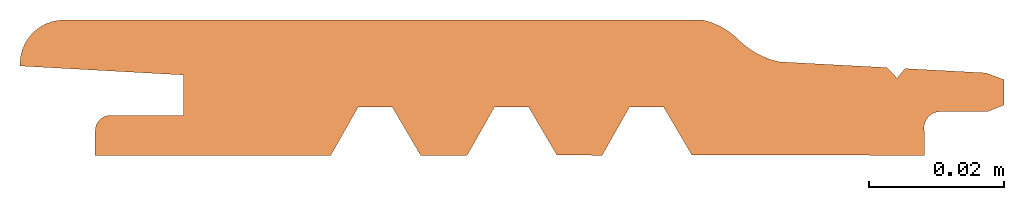
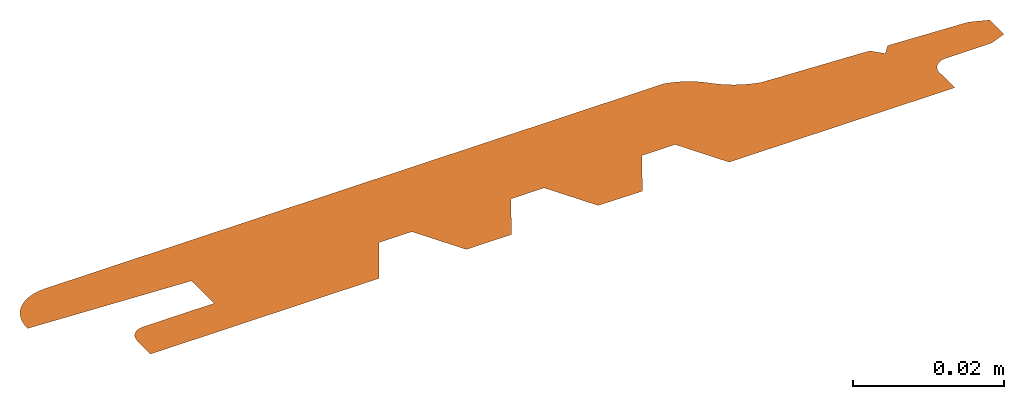
# One storey: 1 proxy.
"""IFC2X3 building model written with IfcOpenShell, lengths in millimetres."""

import ifcopenshell
import ifcopenshell.guid

model = None  # the IFC model being written
_history = None  # IfcOwnerHistory: only IFC2X3 demands one
_inside = {}  # id of a spatial element -> (the spatial element, [elements in it])
_under = {}  # id of a project, library or spatial element -> (it, [spatial elements below it])
_declared = {}  # id of a project -> (the project, [libraries it declares])
_typed = {}  # id of a type object -> (the type object, [elements of that type])
_made_of = {}  # id of a material, layer set ... -> (it, [elements and type objects made of it])


def new_model(schema):
    """Start an empty IFC model of exactly this schema.

    Asked for "IFC4X3", IfcOpenShell would pick the latest addendum, in which some entities
    have other attributes; the version numbers below select the first issue.
    IFC2X3 requires an IfcOwnerHistory on every rooted entity: one is made here for all.
    """
    global model, _history
    if schema == "IFC4X3":
        model = ifcopenshell.file(schema_version=(4, 3, 0, 0))
    else:
        model = ifcopenshell.file(schema=schema)
    _inside.clear()
    _under.clear()
    _declared.clear()
    _typed.clear()
    _made_of.clear()
    _history = None
    if model.schema == "IFC2X3":
        org = make("IfcOrganization", Name="unknown")
        user = make(
            "IfcPersonAndOrganization",
            ThePerson=make("IfcPerson", FamilyName="unknown"),
            TheOrganization=org,
        )
        app = make(
            "IfcApplication",
            ApplicationDeveloper=org,
            Version="unknown",
            ApplicationFullName="unknown",
            ApplicationIdentifier="unknown",
        )
        _history = make(
            "IfcOwnerHistory",
            OwningUser=user,
            OwningApplication=app,
            ChangeAction="ADDED",
            CreationDate=0,
        )
    return model


def make(cls, **values):
    """One entity of the class cls with the attributes given. An attribute that is None is left unset."""
    return model.create_entity(
        cls, **{name: value for name, value in values.items() if value is not None}
    )


def entity(cls, *values):
    """Any entity or typed value of the class cls, its attributes in the order of the schema. None: left unset."""
    e = model.create_entity(cls)
    for i, value in enumerate(values):
        if value is not None:
            e[i] = value
    return e


def rooted(cls, **values):
    """An entity with a GlobalId (a new one), such as an element, a storey or a relation."""
    return make(cls, GlobalId=ifcopenshell.guid.new(), OwnerHistory=_history, **values)


def si_unit(unit_type, name, prefix=None):
    """IfcSIUnit, for example si_unit("LENGTHUNIT", "METRE", prefix="MILLI")."""
    return make("IfcSIUnit", UnitType=unit_type, Prefix=prefix, Name=name)


def converted_unit(unit_type, name, factor, base, dimensions=None, offset=None):
    """IfcConversionBasedUnit, such as the inch: factor (a typed value) times the base unit."""
    return make(
        "IfcConversionBasedUnit"
        if offset is None
        else "IfcConversionBasedUnitWithOffset",
        ConversionOffset=offset,
        Dimensions=None
        if dimensions is None
        else entity("IfcDimensionalExponents", *dimensions),
        UnitType=unit_type,
        Name=name,
        ConversionFactor=make(
            "IfcMeasureWithUnit", ValueComponent=factor, UnitComponent=base
        ),
    )


def assignment(units):
    """IfcUnitAssignment: the units of a project."""
    return None if units is None else make("IfcUnitAssignment", Units=units)


def point(xyz):
    """IfcCartesianPoint."""
    return None if xyz is None else make("IfcCartesianPoint", Coordinates=xyz)


def direction(xyz):
    """IfcDirection."""
    return None if xyz is None else make("IfcDirection", DirectionRatios=xyz)


def frame(location, z_axis=None, x_axis=None):
    """IfcAxis2Placement3D, a coordinate frame: its origin and axes. An axis left out is left unset."""
    return make(
        "IfcAxis2Placement3D",
        Location=point(location),
        Axis=direction(z_axis),
        RefDirection=direction(x_axis),
    )


def origin():
    """The frame at (0, 0, 0) with its axes left unset."""
    return frame((0.0, 0.0, 0.0))


def origin_with_axes():
    """The frame at (0, 0, 0) with the z axis (0, 0, 1) and the x axis (1, 0, 0) written out."""
    return frame((0.0, 0.0, 0.0), z_axis=(0.0, 0.0, 1.0), x_axis=(1.0, 0.0, 0.0))


def place(relative_to, where):
    """IfcLocalPlacement: puts the frame where relative to a parent placement (None: the world)."""
    return make(
        "IfcLocalPlacement", PlacementRelTo=relative_to, RelativePlacement=where
    )


def context(
    kind, dimensions, precision=None, world=None, true_north=None, identifier=None
):
    """IfcGeometricRepresentationContext, for example the 3D "Model" context."""
    return make(
        "IfcGeometricRepresentationContext",
        ContextIdentifier=identifier,
        ContextType=kind,
        CoordinateSpaceDimension=dimensions,
        Precision=precision,
        WorldCoordinateSystem=world,
        TrueNorth=true_north,
    )


def project(units=None, contexts=None):
    """IfcProject with its units and contexts."""
    return rooted(
        "IfcProject",
        Name="project",
        RepresentationContexts=contexts,
        UnitsInContext=assignment(units),
    )


def spatial(cls, under=None, at=None, **own):
    """A site, building, storey or space (cls), placed at a placement, below another one or the project."""
    s = rooted(cls, ObjectPlacement=at, **own)
    if under is not None:
        _under.setdefault(under.id(), (under, []))[1].append(s)
    return s


def faces_of(points, faces, orient=None, outer=None):
    """IfcFace entities. A face is a list of loops; a loop is a list of indices into points, from 0.

    orient and outer hold one flag for each loop. By default every Orientation is true, the
    first loop of a face is its IfcFaceOuterBound and the others are IfcFaceBound.
    """
    made = []
    for i, loops in enumerate(faces):
        bounds = []
        for j, loop in enumerate(loops):
            is_outer = j == 0 if outer is None else outer[i][j]
            bounds.append(
                make(
                    "IfcFaceOuterBound" if is_outer else "IfcFaceBound",
                    Bound=make("IfcPolyLoop", Polygon=[points[k] for k in loop]),
                    Orientation=True if orient is None else orient[i][j],
                )
            )
        made.append(make("IfcFace", Bounds=bounds))
    return made


def faceted_brep(points, faces, orient=None, outer=None, voids=None):
    """IfcFacetedBrep: a solid bounded by flat faces; with voids (closed shells), ...WithVoids."""
    shared = [point(p) for p in points]
    hull = make("IfcClosedShell", CfsFaces=faces_of(shared, faces, orient, outer))
    if voids is None:
        return make("IfcFacetedBrep", Outer=hull)
    return make(
        "IfcFacetedBrepWithVoids",
        Outer=hull,
        Voids=[
            make(cls, CfsFaces=faces_of(shared, fs, o, b)) for cls, fs, o, b in voids
        ],
    )


def shape(context_of_items, identifier, shape_type, items):
    """IfcShapeRepresentation: the items that make up one representation, for example the "Body"."""
    return make(
        "IfcShapeRepresentation",
        ContextOfItems=context_of_items,
        RepresentationIdentifier=identifier,
        RepresentationType=shape_type,
        Items=items,
    )


def made_of(thing, what):
    """Note that an element or type object is made of a material, layer set ...; save() writes the relation."""
    if what is not None:
        _made_of.setdefault(what.id(), (what, []))[1].append(thing)
    return thing


def element(
    cls,
    number,
    at=None,
    inside=None,
    cuts=None,
    type_object=None,
    material=None,
    context=None,
    identifier="Body",
    shape_type=None,
    held_by="IfcProductDefinitionShape",
    body=None,
    shapes=None,
    **own,
):
    """One element of the class cls, such as IfcWall. Its Tag is "e" and its number.

    at: its placement. inside: the storey or other place that contains it. cuts: it is an
    opening in that element (IfcRelVoidsElement). A single representation is given by context,
    identifier, shape_type and body (its items); several are given by shapes. held_by: the class
    of the entity that holds the representations. save() writes the other relations.
    """
    e = rooted(cls, Tag="e%d" % number, ObjectPlacement=at, **own)
    if body is not None:
        shapes = [shape(context, identifier, shape_type, body)]
    if shapes is not None:
        e.Representation = make(held_by, Representations=shapes)
    if inside is not None:
        _inside.setdefault(inside.id(), (inside, []))[1].append(e)
    if cuts is not None:
        rooted(
            "IfcRelVoidsElement", RelatingBuildingElement=cuts, RelatedOpeningElement=e
        )
    if type_object is not None:
        _typed.setdefault(type_object.id(), (type_object, []))[1].append(e)
    return made_of(e, material)


def aggregate(whole, parts):
    """IfcRelAggregates: a whole, such as a stair, and the parts it consists of."""
    return rooted("IfcRelAggregates", RelatingObject=whole, RelatedObjects=parts)


def save(model, path):
    """Write the relations noted so far, then the file.

    IfcRelAggregates (storeys below a building ...), IfcRelContainedInSpatialStructure (elements
    in a storey), IfcRelDefinesByType, IfcRelAssociatesMaterial and IfcRelDeclares: one each for
    every whole, place, type object, material and project.
    """
    for whole, parts in _under.values():
        aggregate(whole, parts)
    for where, things in _inside.values():
        rooted(
            "IfcRelContainedInSpatialStructure",
            RelatedElements=things,
            RelatingStructure=where,
        )
    for kind, things in _typed.values():
        rooted("IfcRelDefinesByType", RelatedObjects=things, RelatingType=kind)
    for what, things in _made_of.values():
        rooted("IfcRelAssociatesMaterial", RelatedObjects=things, RelatingMaterial=what)
    for by, libraries in _declared.values():
        rooted("IfcRelDeclares", RelatingContext=by, RelatedDefinitions=libraries)
    model.write(path)


model = new_model("IFC2X3")

# Units and contexts
model_context = context("Model", 3, precision=1e-05, world=origin(), true_north=direction((0.0, 1.0, 0.0)))
ifc_project = project(units=[si_unit("LENGTHUNIT", "METRE", prefix="MILLI"), si_unit("AREAUNIT", "SQUARE_METRE"), si_unit("VOLUMEUNIT", "CUBIC_METRE"), converted_unit("PLANEANGLEUNIT", "DEGREE", entity("IfcPlaneAngleMeasure", 0.01745), si_unit("PLANEANGLEUNIT", "RADIAN"), dimensions=[0, 0, 0, 0, 0, 0, 0]), si_unit("SOLIDANGLEUNIT", "STERADIAN"), si_unit("MASSUNIT", "GRAM"), si_unit("TIMEUNIT", "SECOND"), si_unit("THERMODYNAMICTEMPERATUREUNIT", "DEGREE_CELSIUS"), si_unit("LUMINOUSINTENSITYUNIT", "LUMEN")], contexts=[model_context])

# Site, building, storey
site_placement = place(None, origin_with_axes())
site = spatial("IfcSite", under=ifc_project, at=site_placement, CompositionType="ELEMENT")
building_placement = place(site_placement, origin_with_axes())
building = spatial("IfcBuilding", under=site, at=building_placement, Name="Default Building", CompositionType="ELEMENT")
storey_placement = place(building_placement, origin_with_axes())
storey = spatial("IfcBuildingStorey", under=building, at=storey_placement, Name="Default Building Storey", CompositionType="ELEMENT", Elevation=0.0)

# Proxy
proxy_placement = place(storey_placement, origin_with_axes())
element("IfcBuildingElementProxy", 1, at=proxy_placement, inside=storey, context=model_context, shape_type="Brep", body=[
    faceted_brep([(95.48603468643138, 7.160832846953072, 9.023892744153272e-14), (99.65629669804873, 0.0622728380424256, 0.0), (134.1438229257196, 0.0, 0.0), (134.1438229257196, 3.591033600000017, 0.0), (134.1072316435527, 3.947279846267111, 1.127986593019159e-14), (134.1226750498892, 4.305067228815418, 2.255973186038318e-14), (134.189826818947, 4.656835547204644, 3.31346061699378e-14), (134.3072680051213, 4.995151786395375, 4.370948047949241e-14), (134.4725170259116, 5.31286717953494, 5.357936316841005e-14), (134.6820820988214, 5.603268264460913, 6.274425423669072e-14), (134.9315350242171, 5.860218742027138, 7.049916206369744e-14), (135.2156047550795, 6.078289138729651, 7.754907827006718e-14), (135.5282887764812, 6.252871533803985, 8.318901123516297e-14), (135.8629799412971, 6.380276926563335, 8.671396933834785e-14), (136.212606082047, 6.45781318656025, 8.953393582089574e-14), (136.5697794488213, 6.483841939452999, 9.023892744153272e-14), (143.5033599488213, 6.483841939452999, 9.023892744153272e-14), (145.9739819889328, 7.472820287462014, 0.0), (145.9739819889328, 11.22416788746193, 0.0), (143.2947497079596, 12.22940268008348, 0.0), (131.2935244960869, 12.87250863867312, 0.0), (130.1101740481729, 11.45573640260452, 0.0), (128.6106255743134, 13.01627631675826, 0.0), (112.6225938015262, 13.87302205043779, 0.0), (112.0604585361125, 14.01055139214958, 3.524958103184872e-15), (111.5054098715244, 14.17435418941584, 8.459899447643692e-15), (110.958675065994, 14.36406826078394, 1.339484079210251e-14), (110.4214629951279, 14.57927413284436, 1.973976537783528e-14), (109.8949614789836, 14.81949596772003, 2.608468996356805e-14), (109.380334655701, 15.08420261518353, 3.31346061699378e-14), (108.8787204074979, 15.37280878707363, 4.159450561758149e-14), (108.391227844719, 15.68467635141597, 5.005440506522518e-14), (107.9189348535013, 16.01911574338413, 5.921929613350585e-14), (107.4628857124793, 16.37538748998574, 6.908917882242349e-14), (107.0240887837996, 16.75270384509688, 7.895906151134113e-14), (106.6035142835479, 17.15023053123463, 9.023892744153272e-14), (106.2277026833233, 17.50544735954961, 6.133427099541677e-14), (105.8356081178128, 17.84260489791803, 3.877453913503359e-14), (105.4280975403383, 18.1609576633023, 2.255973186038318e-14), (105.0060719902911, 18.45980175156402, 1.339484079210251e-14), (104.5704646008607, 18.73847639385341, 1.057487430955462e-14), (104.1222385357997, 18.99636541762425, 1.409983241273949e-14), (103.6623848597904, 19.23289860904204, 2.396971510165713e-14), (103.1919203471184, 19.44755297377299, 4.018452237630754e-14), (102.7118852335027, 19.63985389336834, 6.34492458573277e-14), (102.2233409160464, 19.80937617468461, 9.305889392408061e-14), (101.7273676064026, 19.95574499001939, 1.283084749559293e-13), (101.2250619423371, 20.07863670588825, 1.706079721941478e-13), (6.511550742337135, 20.07863670588825, 1.706079721941478e-13), (5.635699598913434, 20.01952803985278, 1.473432487131276e-13), (4.77573240502563, 19.84327400366048, 1.254885084733814e-13), (3.947245047729431, 19.55307104254978, 1.036337682336352e-13), (3.165262513260452, 19.1541821161268, 8.318901123516297e-14), (2.443966402235358, 18.653841252258, 6.415423747796467e-14), (1.796437740024599, 18.0611223547587, 4.723443858267728e-14), (1.234419746547418, 17.38677464411902, 3.242961454930082e-14), (0.768104867761917, 16.64302771561378, 2.044475699847226e-14), (0.4059499311303202, 15.84336975016214, 1.057487430955462e-14), (0.1545227772963759, 15.00230290017204, 4.229949723821846e-15), (0.01838314937785785, 14.13508028656742, 7.049916206369744e-16), (0.0, 13.25742937666294, 0.0), (24.25888491376742, 11.92250022581039, 0.0), (24.25888491376742, 5.934772325810123, 0.0), (13.53387831376758, 5.934772325810123, 0.0), (13.22221942187708, 5.922574513849828, 0.0), (12.92039036681607, 5.875128176208709, 0.0), (12.62773331458978, 5.787356978103787, 0.0), (12.34960978185459, 5.660868899718923, 0.0), (12.09111502923055, 5.49798121970463, 0.0), (11.85698471543932, 5.301678062321489, 0.0), (11.6515081393978, 5.07555572788092, 0.0), (11.4784496596843, 4.823756808038652, 0.0), (11.3409797309809, 4.550894292956588, 0.0), (11.24161682091701, 4.261967060702137, 0.0), (11.18218127140227, 3.962268297126937, 0.0), (11.16376194971793, 3.657288523988976, 0.0), (11.09481222572007, 3.591033600000017, 0.0), (11.09481222572007, 0.0, 0.0), (46.10025152572641, 0.0, 0.0), (50.16265381792222, 7.160832846953072, 9.023892744153272e-14), (55.22890690878848, 7.160832846953072, 9.023892744153272e-14), (59.39916892040587, 0.0622728380424256, 0.0), (59.43575296710237, 0.0, 0.0), (66.32952538994341, 0.0, 0.0), (70.39192768213935, 7.160832846953072, 9.023892744153272e-14), (75.45818077300584, 7.160832846953072, 9.023892744153272e-14), (79.628442784623, 0.0622728380424256, 0.0), (86.35737930336914, 0.0, 0.0), (90.41978159556507, 7.160832846953072, 9.023892744153272e-14)], [[[0, 1, 2, 3, 4, 5, 6, 7, 8, 9, 10, 11, 12, 13, 14, 15, 16, 17, 18, 19, 20, 21, 22, 23, 24, 25, 26, 27, 28, 29, 30, 31, 32, 33, 34, 35, 36, 37, 38, 39, 40, 41, 42, 43, 44, 45, 46, 47, 48, 49, 50, 51, 52, 53, 54, 55, 56, 57, 58, 59, 60, 61, 62, 63, 64, 65, 66, 67, 68, 69, 70, 71, 72, 73, 74, 75, 76, 77, 78, 79, 80, 81, 82, 83, 84, 85, 86, 87, 88]]]),
])

save(model, "model.ifc")
